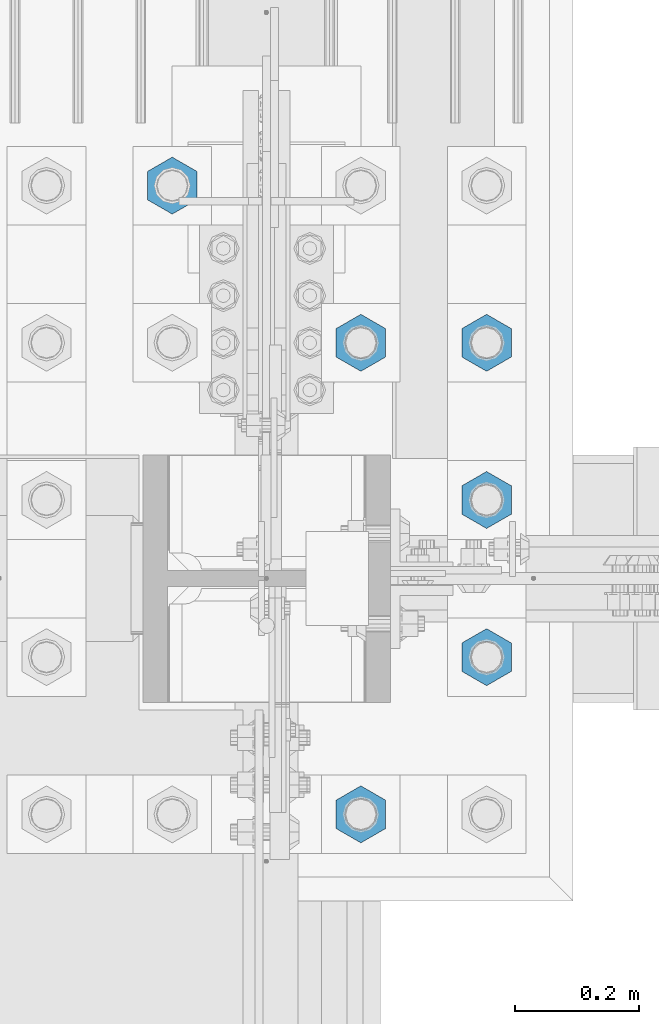
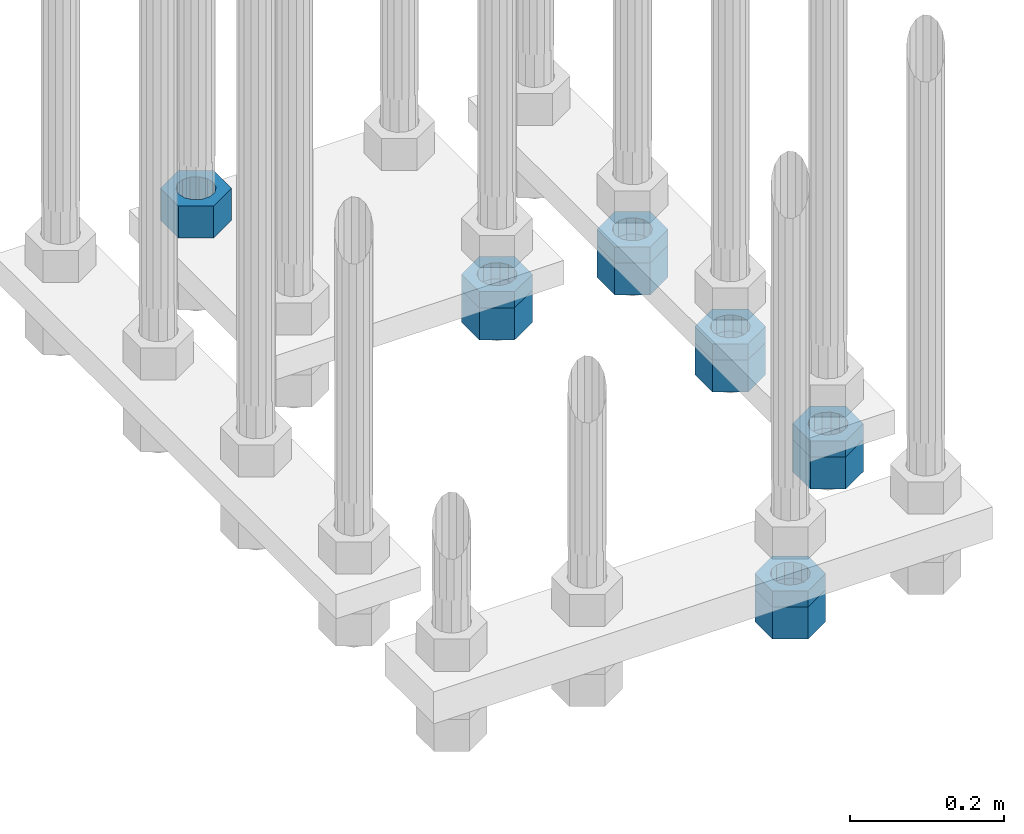
# One storey, part 2369 of 3843: 11 beams, 1 element without a shape of its own.
"""IFC2X3 building model written with IfcOpenShell, lengths in millimetres."""

from ifc_helpers import new_model, si_unit, frame, origin_with_axes, place, context, subcontext, project, spatial, faceted_brep, material, type_object, element, aggregate, save


model = new_model("IFC2X3")

# Units and contexts
model_context = context("Model", 3, precision=1e-05, world=origin_with_axes())
body_context = subcontext(model_context, "Body", "Model", "MODEL_VIEW")
ifc_project = project(units=[si_unit("LENGTHUNIT", "METRE", prefix="MILLI"), si_unit("AREAUNIT", "SQUARE_METRE"), si_unit("VOLUMEUNIT", "CUBIC_METRE"), si_unit("MASSUNIT", "GRAM", prefix="KILO"), si_unit("TIMEUNIT", "SECOND"), si_unit("PLANEANGLEUNIT", "RADIAN"), si_unit("SOLIDANGLEUNIT", "STERADIAN"), si_unit("THERMODYNAMICTEMPERATUREUNIT", "DEGREE_CELSIUS"), si_unit("LUMINOUSINTENSITYUNIT", "LUMEN")], contexts=[model_context])

# Site, building, storey
site_placement = place(None, origin_with_axes())
site = spatial("IfcSite", under=ifc_project, at=site_placement, CompositionType="ELEMENT")
building_placement = place(site_placement, origin_with_axes())
building = spatial("IfcBuilding", under=site, at=building_placement, Name="Undefined", CompositionType="ELEMENT")
storey_placement = place(building_placement, origin_with_axes())
storey = spatial("IfcBuildingStorey", under=building, at=storey_placement, Name="Undefined", CompositionType="ELEMENT", Elevation=0.0)

# Assembly, beams
assembly_placement = place(storey_placement, origin_with_axes())
assembly = element("IfcElementAssembly", 1, at=assembly_placement, inside=storey, Name="TEMPLATE", AssemblyPlace="NOTDEFINED", PredefinedType="RIGID_FRAME")
ifc_material = material(Name="STEEL/A572-50")
beam_type_1 = type_object("IfcBeamType", Name="2_HALF_NUT", PredefinedType="NOTDEFINED")
beam_1_placement = place(assembly_placement, frame((36728.4, 66890.9, 29057.6), z_axis=(1.0, 0.0, 0.0), x_axis=(0.0, 0.0, -1.0)))
beam_1 = element("IfcBeam", 2, at=beam_1_placement, type_object=beam_type_1, material=ifc_material, Name="NUT", ObjectType="2_HALF_NUT", context=body_context, shape_type="Brep", body=[
    faceted_brep([(0.0, -46.0369987487793, 0.0), (0.0, -23.0184993743896, -39.869213104248), (25.4000000000015, -23.0184993743896, -39.869213104248), (25.4000000000015, -46.0369987487793, 0.0), (0.0, 23.0184993743896, -39.869213104248), (25.4000000000015, 23.0184993743896, -39.869213104248), (0.0, 46.0369987487793, 0.0), (25.4000000000015, 46.0369987487793, 0.0), (0.0, 23.0184993743896, 39.869213104248), (25.4000000000015, 23.0184993743896, 39.869213104248), (0.0, -23.0184993743896, 39.869213104248), (25.4000000000015, -23.0184993743896, 39.869213104248), (0.0, 0.0, 26.1940002441406), (0.0, 11.3650617044477, 23.5999013092805), (25.4000000000015, 11.3650617044477, 23.5999013092805), (25.4000000000015, 0.0, 26.1940002441406), (0.0, 20.4791109456419, 16.3316083006721), (25.4000000000015, 20.4791109456419, 16.3316083006721), (0.0, 25.5370200498292, 5.82867859874386), (25.4000000000015, 25.5370200498292, 5.82867859874386), (0.0, 25.5370200498292, -5.82867859874386), (25.4000000000015, 25.5370200498292, -5.82867859874386), (0.0, 20.4791109456419, -16.3316083006721), (25.4000000000015, 20.4791109456419, -16.3316083006721), (0.0, 11.3650617044477, -23.5999013092805), (25.4000000000015, 11.3650617044477, -23.5999013092805), (0.0, 0.0, -26.1940002441406), (25.4000000000015, 0.0, -26.1940002441406), (0.0, -11.3650617044477, -23.5999013092805), (25.4000000000015, -11.3650617044477, -23.5999013092805), (0.0, -20.4791109456419, -16.3316083006721), (25.4000000000015, -20.4791109456419, -16.3316083006721), (0.0, -25.5370200498292, -5.82867859874386), (25.4000000000015, -25.5370200498292, -5.82867859874386), (0.0, -25.5370200498292, 5.82867859874386), (25.4000000000015, -25.5370200498292, 5.82867859874386), (0.0, -20.4791109456419, 16.3316083006721), (25.4000000000015, -20.4791109456419, 16.3316083006721), (0.0, -11.3650617044477, 23.5999013092805), (25.4000000000015, -11.3650617044477, 23.5999013092805)], [[[0, 1, 2, 3]], [[1, 4, 5, 2]], [[4, 6, 7, 5]], [[6, 8, 9, 7]], [[8, 10, 11, 9]], [[10, 0, 3, 11]], [[12, 13, 14, 15]], [[13, 16, 17, 14]], [[16, 18, 19, 17]], [[18, 20, 21, 19]], [[20, 22, 23, 21]], [[22, 24, 25, 23]], [[24, 26, 27, 25]], [[26, 28, 29, 27]], [[28, 30, 31, 29]], [[30, 32, 33, 31]], [[32, 34, 35, 33]], [[34, 36, 37, 35]], [[36, 38, 39, 37]], [[38, 12, 15, 39]], [[5, 7, 9, 11, 3, 2], [17, 19, 21, 23, 25, 27, 29, 31, 33, 35, 37, 39, 15, 14]], [[10, 8, 6, 4, 1, 0], [38, 36, 34, 32, 30, 28, 26, 24, 22, 20, 18, 16, 13, 12]]]),
])
beam_2_placement = place(assembly_placement, frame((36728.4, 67652.9, 29070.3), z_axis=(-1.0, 0.0, 0.0), x_axis=(0.0, 0.0, -1.0)))
beam_2 = element("IfcBeam", 3, at=beam_2_placement, type_object=beam_type_1, material=ifc_material, Name="NUT", ObjectType="2_HALF_NUT", context=body_context, shape_type="Brep", body=[
    faceted_brep([(0.0, -46.0369987487793, 0.0), (0.0, -23.0184993743896, -39.869213104248), (25.4000000000015, -23.0184993743896, -39.869213104248), (25.4000000000015, -46.0369987487793, 0.0), (0.0, 23.0184993743896, -39.869213104248), (25.4000000000015, 23.0184993743896, -39.869213104248), (0.0, 46.0369987487793, 0.0), (25.4000000000015, 46.0369987487793, 0.0), (0.0, 23.0184993743896, 39.869213104248), (25.4000000000015, 23.0184993743896, 39.869213104248), (0.0, -23.0184993743896, 39.869213104248), (25.4000000000015, -23.0184993743896, 39.869213104248), (0.0, 0.0, 26.1940002441406), (0.0, 11.3650617044477, 23.5999013092805), (25.4000000000015, 11.3650617044477, 23.5999013092805), (25.4000000000015, 0.0, 26.1940002441406), (0.0, 20.4791109456419, 16.3316083006721), (25.4000000000015, 20.4791109456419, 16.3316083006721), (0.0, 25.5370200498292, 5.82867859874386), (25.4000000000015, 25.5370200498292, 5.82867859874386), (0.0, 25.5370200498292, -5.82867859874386), (25.4000000000015, 25.5370200498292, -5.82867859874386), (0.0, 20.4791109456419, -16.3316083006721), (25.4000000000015, 20.4791109456419, -16.3316083006721), (0.0, 11.3650617044477, -23.5999013092805), (25.4000000000015, 11.3650617044477, -23.5999013092805), (0.0, 0.0, -26.1940002441406), (25.4000000000015, 0.0, -26.1940002441406), (0.0, -11.3650617044477, -23.5999013092805), (25.4000000000015, -11.3650617044477, -23.5999013092805), (0.0, -20.4791109456419, -16.3316083006721), (25.4000000000015, -20.4791109456419, -16.3316083006721), (0.0, -25.5370200498292, -5.82867859874386), (25.4000000000015, -25.5370200498292, -5.82867859874386), (0.0, -25.5370200498292, 5.82867859874386), (25.4000000000015, -25.5370200498292, 5.82867859874386), (0.0, -20.4791109456419, 16.3316083006721), (25.4000000000015, -20.4791109456419, 16.3316083006721), (0.0, -11.3650617044477, 23.5999013092805), (25.4000000000015, -11.3650617044477, 23.5999013092805)], [[[0, 1, 2, 3]], [[1, 4, 5, 2]], [[4, 6, 7, 5]], [[6, 8, 9, 7]], [[8, 10, 11, 9]], [[10, 0, 3, 11]], [[12, 13, 14, 15]], [[13, 16, 17, 14]], [[16, 18, 19, 17]], [[18, 20, 21, 19]], [[20, 22, 23, 21]], [[22, 24, 25, 23]], [[24, 26, 27, 25]], [[26, 28, 29, 27]], [[28, 30, 31, 29]], [[30, 32, 33, 31]], [[32, 34, 35, 33]], [[34, 36, 37, 35]], [[36, 38, 39, 37]], [[38, 12, 15, 39]], [[5, 7, 9, 11, 3, 2], [17, 19, 21, 23, 25, 27, 29, 31, 33, 35, 37, 39, 15, 14]], [[10, 8, 6, 4, 1, 0], [38, 36, 34, 32, 30, 28, 26, 24, 22, 20, 18, 16, 13, 12]]]),
])
beam_3_placement = place(assembly_placement, frame((36931.6, 67144.9, 29070.3), z_axis=(1.0, 0.0, 0.0), x_axis=(0.0, 0.0, -1.0)))
beam_3 = element("IfcBeam", 4, at=beam_3_placement, type_object=beam_type_1, material=ifc_material, Name="NUT", ObjectType="2_HALF_NUT", context=body_context, shape_type="Brep", body=[
    faceted_brep([(0.0, -46.0369987487793, 0.0), (0.0, -23.0184993743896, -39.869213104248), (25.4000000000015, -23.0184993743896, -39.869213104248), (25.4000000000015, -46.0369987487793, 0.0), (0.0, 23.0184993743896, -39.869213104248), (25.4000000000015, 23.0184993743896, -39.869213104248), (0.0, 46.0369987487793, 0.0), (25.4000000000015, 46.0369987487793, 0.0), (0.0, 23.0184993743896, 39.869213104248), (25.4000000000015, 23.0184993743896, 39.869213104248), (0.0, -23.0184993743896, 39.869213104248), (25.4000000000015, -23.0184993743896, 39.869213104248), (0.0, 0.0, 26.1940002441406), (0.0, 11.3650617044477, 23.5999013092805), (25.4000000000015, 11.3650617044477, 23.5999013092805), (25.4000000000015, 0.0, 26.1940002441406), (0.0, 20.4791109456419, 16.3316083006721), (25.4000000000015, 20.4791109456419, 16.3316083006721), (0.0, 25.5370200498292, 5.82867859874386), (25.4000000000015, 25.5370200498292, 5.82867859874386), (0.0, 25.5370200498292, -5.82867859874386), (25.4000000000015, 25.5370200498292, -5.82867859874386), (0.0, 20.4791109456419, -16.3316083006721), (25.4000000000015, 20.4791109456419, -16.3316083006721), (0.0, 11.3650617044477, -23.5999013092805), (25.4000000000015, 11.3650617044477, -23.5999013092805), (0.0, 0.0, -26.1940002441406), (25.4000000000015, 0.0, -26.1940002441406), (0.0, -11.3650617044477, -23.5999013092805), (25.4000000000015, -11.3650617044477, -23.5999013092805), (0.0, -20.4791109456419, -16.3316083006721), (25.4000000000015, -20.4791109456419, -16.3316083006721), (0.0, -25.5370200498292, -5.82867859874386), (25.4000000000015, -25.5370200498292, -5.82867859874386), (0.0, -25.5370200498292, 5.82867859874386), (25.4000000000015, -25.5370200498292, 5.82867859874386), (0.0, -20.4791109456419, 16.3316083006721), (25.4000000000015, -20.4791109456419, 16.3316083006721), (0.0, -11.3650617044477, 23.5999013092805), (25.4000000000015, -11.3650617044477, 23.5999013092805)], [[[0, 1, 2, 3]], [[1, 4, 5, 2]], [[4, 6, 7, 5]], [[6, 8, 9, 7]], [[8, 10, 11, 9]], [[10, 0, 3, 11]], [[12, 13, 14, 15]], [[13, 16, 17, 14]], [[16, 18, 19, 17]], [[18, 20, 21, 19]], [[20, 22, 23, 21]], [[22, 24, 25, 23]], [[24, 26, 27, 25]], [[26, 28, 29, 27]], [[28, 30, 31, 29]], [[30, 32, 33, 31]], [[32, 34, 35, 33]], [[34, 36, 37, 35]], [[36, 38, 39, 37]], [[38, 12, 15, 39]], [[5, 7, 9, 11, 3, 2], [17, 19, 21, 23, 25, 27, 29, 31, 33, 35, 37, 39, 15, 14]], [[10, 8, 6, 4, 1, 0], [38, 36, 34, 32, 30, 28, 26, 24, 22, 20, 18, 16, 13, 12]]]),
])
beam_4_placement = place(assembly_placement, frame((36931.6, 67398.9, 29070.3), z_axis=(1.0, 0.0, 0.0), x_axis=(0.0, 0.0, -1.0)))
beam_4 = element("IfcBeam", 5, at=beam_4_placement, type_object=beam_type_1, material=ifc_material, Name="NUT", ObjectType="2_HALF_NUT", context=body_context, shape_type="Brep", body=[
    faceted_brep([(0.0, -46.0369987487793, 0.0), (0.0, -23.0184993743896, -39.869213104248), (25.4000000000015, -23.0184993743896, -39.869213104248), (25.4000000000015, -46.0369987487793, 0.0), (0.0, 23.0184993743896, -39.869213104248), (25.4000000000015, 23.0184993743896, -39.869213104248), (0.0, 46.0369987487793, 0.0), (25.4000000000015, 46.0369987487793, 0.0), (0.0, 23.0184993743896, 39.869213104248), (25.4000000000015, 23.0184993743896, 39.869213104248), (0.0, -23.0184993743896, 39.869213104248), (25.4000000000015, -23.0184993743896, 39.869213104248), (0.0, 0.0, 26.1940002441406), (0.0, 11.3650617044477, 23.5999013092805), (25.4000000000015, 11.3650617044477, 23.5999013092805), (25.4000000000015, 0.0, 26.1940002441406), (0.0, 20.4791109456419, 16.3316083006721), (25.4000000000015, 20.4791109456419, 16.3316083006721), (0.0, 25.5370200498292, 5.82867859874386), (25.4000000000015, 25.5370200498292, 5.82867859874386), (0.0, 25.5370200498292, -5.82867859874386), (25.4000000000015, 25.5370200498292, -5.82867859874386), (0.0, 20.4791109456419, -16.3316083006721), (25.4000000000015, 20.4791109456419, -16.3316083006721), (0.0, 11.3650617044477, -23.5999013092805), (25.4000000000015, 11.3650617044477, -23.5999013092805), (0.0, 0.0, -26.1940002441406), (25.4000000000015, 0.0, -26.1940002441406), (0.0, -11.3650617044477, -23.5999013092805), (25.4000000000015, -11.3650617044477, -23.5999013092805), (0.0, -20.4791109456419, -16.3316083006721), (25.4000000000015, -20.4791109456419, -16.3316083006721), (0.0, -25.5370200498292, -5.82867859874386), (25.4000000000015, -25.5370200498292, -5.82867859874386), (0.0, -25.5370200498292, 5.82867859874386), (25.4000000000015, -25.5370200498292, 5.82867859874386), (0.0, -20.4791109456419, 16.3316083006721), (25.4000000000015, -20.4791109456419, 16.3316083006721), (0.0, -11.3650617044477, 23.5999013092805), (25.4000000000015, -11.3650617044477, 23.5999013092805)], [[[0, 1, 2, 3]], [[1, 4, 5, 2]], [[4, 6, 7, 5]], [[6, 8, 9, 7]], [[8, 10, 11, 9]], [[10, 0, 3, 11]], [[12, 13, 14, 15]], [[13, 16, 17, 14]], [[16, 18, 19, 17]], [[18, 20, 21, 19]], [[20, 22, 23, 21]], [[22, 24, 25, 23]], [[24, 26, 27, 25]], [[26, 28, 29, 27]], [[28, 30, 31, 29]], [[30, 32, 33, 31]], [[32, 34, 35, 33]], [[34, 36, 37, 35]], [[36, 38, 39, 37]], [[38, 12, 15, 39]], [[5, 7, 9, 11, 3, 2], [17, 19, 21, 23, 25, 27, 29, 31, 33, 35, 37, 39, 15, 14]], [[10, 8, 6, 4, 1, 0], [38, 36, 34, 32, 30, 28, 26, 24, 22, 20, 18, 16, 13, 12]]]),
])
beam_5_placement = place(assembly_placement, frame((36931.6, 67652.9, 29070.3), z_axis=(-1.0, 0.0, 0.0), x_axis=(0.0, 0.0, -1.0)))
beam_5 = element("IfcBeam", 6, at=beam_5_placement, type_object=beam_type_1, material=ifc_material, Name="NUT", ObjectType="2_HALF_NUT", context=body_context, shape_type="Brep", body=[
    faceted_brep([(0.0, -46.0369987487793, 0.0), (0.0, -23.0184993743896, -39.869213104248), (25.4000000000015, -23.0184993743896, -39.869213104248), (25.4000000000015, -46.0369987487793, 0.0), (0.0, 23.0184993743896, -39.869213104248), (25.4000000000015, 23.0184993743896, -39.869213104248), (0.0, 46.0369987487793, 0.0), (25.4000000000015, 46.0369987487793, 0.0), (0.0, 23.0184993743896, 39.869213104248), (25.4000000000015, 23.0184993743896, 39.869213104248), (0.0, -23.0184993743896, 39.869213104248), (25.4000000000015, -23.0184993743896, 39.869213104248), (0.0, 0.0, 26.1940002441406), (0.0, 11.3650617044477, 23.5999013092805), (25.4000000000015, 11.3650617044477, 23.5999013092805), (25.4000000000015, 0.0, 26.1940002441406), (0.0, 20.4791109456419, 16.3316083006721), (25.4000000000015, 20.4791109456419, 16.3316083006721), (0.0, 25.5370200498292, 5.82867859874386), (25.4000000000015, 25.5370200498292, 5.82867859874386), (0.0, 25.5370200498292, -5.82867859874386), (25.4000000000015, 25.5370200498292, -5.82867859874386), (0.0, 20.4791109456419, -16.3316083006721), (25.4000000000015, 20.4791109456419, -16.3316083006721), (0.0, 11.3650617044477, -23.5999013092805), (25.4000000000015, 11.3650617044477, -23.5999013092805), (0.0, 0.0, -26.1940002441406), (25.4000000000015, 0.0, -26.1940002441406), (0.0, -11.3650617044477, -23.5999013092805), (25.4000000000015, -11.3650617044477, -23.5999013092805), (0.0, -20.4791109456419, -16.3316083006721), (25.4000000000015, -20.4791109456419, -16.3316083006721), (0.0, -25.5370200498292, -5.82867859874386), (25.4000000000015, -25.5370200498292, -5.82867859874386), (0.0, -25.5370200498292, 5.82867859874386), (25.4000000000015, -25.5370200498292, 5.82867859874386), (0.0, -20.4791109456419, 16.3316083006721), (25.4000000000015, -20.4791109456419, 16.3316083006721), (0.0, -11.3650617044477, 23.5999013092805), (25.4000000000015, -11.3650617044477, 23.5999013092805)], [[[0, 1, 2, 3]], [[1, 4, 5, 2]], [[4, 6, 7, 5]], [[6, 8, 9, 7]], [[8, 10, 11, 9]], [[10, 0, 3, 11]], [[12, 13, 14, 15]], [[13, 16, 17, 14]], [[16, 18, 19, 17]], [[18, 20, 21, 19]], [[20, 22, 23, 21]], [[22, 24, 25, 23]], [[24, 26, 27, 25]], [[26, 28, 29, 27]], [[28, 30, 31, 29]], [[30, 32, 33, 31]], [[32, 34, 35, 33]], [[34, 36, 37, 35]], [[36, 38, 39, 37]], [[38, 12, 15, 39]], [[5, 7, 9, 11, 3, 2], [17, 19, 21, 23, 25, 27, 29, 31, 33, 35, 37, 39, 15, 14]], [[10, 8, 6, 4, 1, 0], [38, 36, 34, 32, 30, 28, 26, 24, 22, 20, 18, 16, 13, 12]]]),
])
beam_type_2 = type_object("IfcBeamType", Name="2_HEAVY_HEX_NUT", PredefinedType="NOTDEFINED")
beam_6_placement = place(assembly_placement, frame((36423.6, 67906.9, 29159.2), z_axis=(-1.0, 0.0, 0.0), x_axis=(0.0, 0.0, -1.0)))
beam_6 = element("IfcBeam", 7, at=beam_6_placement, type_object=beam_type_2, material=ifc_material, Name="NUT", ObjectType="2_HEAVY_HEX_NUT", context=body_context, shape_type="Brep", body=[
    faceted_brep([(0.0, -46.0369987487793, 0.0), (0.0, -23.0184993743896, -39.869213104248), (50.7999999999993, -23.0184993743896, -39.869213104248), (50.7999999999993, -46.0369987487793, 0.0), (0.0, 23.0184993743896, -39.869213104248), (50.7999999999993, 23.0184993743896, -39.869213104248), (0.0, 46.0369987487793, 0.0), (50.7999999999993, 46.0369987487793, 0.0), (0.0, 23.0184993743896, 39.869213104248), (50.7999999999993, 23.0184993743896, 39.869213104248), (0.0, -23.0184993743896, 39.869213104248), (50.7999999999993, -23.0184993743896, 39.869213104248), (0.0, 0.0, 26.1940002441406), (0.0, 11.3650617044477, 23.5999013092805), (50.7999999999993, 11.3650617044477, 23.5999013092805), (50.7999999999993, 0.0, 26.1940002441406), (0.0, 20.4791109456419, 16.3316083006721), (50.7999999999993, 20.4791109456419, 16.3316083006721), (0.0, 25.5370200498292, 5.82867859874386), (50.7999999999993, 25.5370200498292, 5.82867859874386), (0.0, 25.5370200498292, -5.82867859874386), (50.7999999999993, 25.5370200498292, -5.82867859874386), (0.0, 20.4791109456419, -16.3316083006721), (50.7999999999993, 20.4791109456419, -16.3316083006721), (0.0, 11.3650617044477, -23.5999013092805), (50.7999999999993, 11.3650617044477, -23.5999013092805), (0.0, 0.0, -26.1940002441406), (50.7999999999993, 0.0, -26.1940002441406), (0.0, -11.3650617044477, -23.5999013092805), (50.7999999999993, -11.3650617044477, -23.5999013092805), (0.0, -20.4791109456419, -16.3316083006721), (50.7999999999993, -20.4791109456419, -16.3316083006721), (0.0, -25.5370200498292, -5.82867859874386), (50.7999999999993, -25.5370200498292, -5.82867859874386), (0.0, -25.5370200498292, 5.82867859874386), (50.7999999999993, -25.5370200498292, 5.82867859874386), (0.0, -20.4791109456419, 16.3316083006721), (50.7999999999993, -20.4791109456419, 16.3316083006721), (0.0, -11.3650617044477, 23.5999013092805), (50.7999999999993, -11.3650617044477, 23.5999013092805)], [[[0, 1, 2, 3]], [[1, 4, 5, 2]], [[4, 6, 7, 5]], [[6, 8, 9, 7]], [[8, 10, 11, 9]], [[10, 0, 3, 11]], [[12, 13, 14, 15]], [[13, 16, 17, 14]], [[16, 18, 19, 17]], [[18, 20, 21, 19]], [[20, 22, 23, 21]], [[22, 24, 25, 23]], [[24, 26, 27, 25]], [[26, 28, 29, 27]], [[28, 30, 31, 29]], [[30, 32, 33, 31]], [[32, 34, 35, 33]], [[34, 36, 37, 35]], [[36, 38, 39, 37]], [[38, 12, 15, 39]], [[5, 7, 9, 11, 3, 2], [17, 19, 21, 23, 25, 27, 29, 31, 33, 35, 37, 39, 15, 14]], [[10, 8, 6, 4, 1, 0], [38, 36, 34, 32, 30, 28, 26, 24, 22, 20, 18, 16, 13, 12]]]),
])
beam_7_placement = place(assembly_placement, frame((36728.4, 66890.9, 29032.2), z_axis=(1.0, 0.0, 0.0), x_axis=(0.0, 0.0, -1.0)))
beam_7 = element("IfcBeam", 8, at=beam_7_placement, type_object=beam_type_2, material=ifc_material, Name="NUT", ObjectType="2_HEAVY_HEX_NUT", context=body_context, shape_type="Brep", body=[
    faceted_brep([(0.0, -46.0369987487793, 0.0), (0.0, -23.0184993743896, -39.869213104248), (50.7999999999993, -23.0184993743896, -39.869213104248), (50.7999999999993, -46.0369987487793, 0.0), (0.0, 23.0184993743896, -39.869213104248), (50.7999999999993, 23.0184993743896, -39.869213104248), (0.0, 46.0369987487793, 0.0), (50.7999999999993, 46.0369987487793, 0.0), (0.0, 23.0184993743896, 39.869213104248), (50.7999999999993, 23.0184993743896, 39.869213104248), (0.0, -23.0184993743896, 39.869213104248), (50.7999999999993, -23.0184993743896, 39.869213104248), (0.0, 0.0, 26.1940002441406), (0.0, 11.3650617044477, 23.5999013092805), (50.7999999999993, 11.3650617044477, 23.5999013092805), (50.7999999999993, 0.0, 26.1940002441406), (0.0, 20.4791109456419, 16.3316083006721), (50.7999999999993, 20.4791109456419, 16.3316083006721), (0.0, 25.5370200498292, 5.82867859874386), (50.7999999999993, 25.5370200498292, 5.82867859874386), (0.0, 25.5370200498292, -5.82867859874386), (50.7999999999993, 25.5370200498292, -5.82867859874386), (0.0, 20.4791109456419, -16.3316083006721), (50.7999999999993, 20.4791109456419, -16.3316083006721), (0.0, 11.3650617044477, -23.5999013092805), (50.7999999999993, 11.3650617044477, -23.5999013092805), (0.0, 0.0, -26.1940002441406), (50.7999999999993, 0.0, -26.1940002441406), (0.0, -11.3650617044477, -23.5999013092805), (50.7999999999993, -11.3650617044477, -23.5999013092805), (0.0, -20.4791109456419, -16.3316083006721), (50.7999999999993, -20.4791109456419, -16.3316083006721), (0.0, -25.5370200498292, -5.82867859874386), (50.7999999999993, -25.5370200498292, -5.82867859874386), (0.0, -25.5370200498292, 5.82867859874386), (50.7999999999993, -25.5370200498292, 5.82867859874386), (0.0, -20.4791109456419, 16.3316083006721), (50.7999999999993, -20.4791109456419, 16.3316083006721), (0.0, -11.3650617044477, 23.5999013092805), (50.7999999999993, -11.3650617044477, 23.5999013092805)], [[[0, 1, 2, 3]], [[1, 4, 5, 2]], [[4, 6, 7, 5]], [[6, 8, 9, 7]], [[8, 10, 11, 9]], [[10, 0, 3, 11]], [[12, 13, 14, 15]], [[13, 16, 17, 14]], [[16, 18, 19, 17]], [[18, 20, 21, 19]], [[20, 22, 23, 21]], [[22, 24, 25, 23]], [[24, 26, 27, 25]], [[26, 28, 29, 27]], [[28, 30, 31, 29]], [[30, 32, 33, 31]], [[32, 34, 35, 33]], [[34, 36, 37, 35]], [[36, 38, 39, 37]], [[38, 12, 15, 39]], [[5, 7, 9, 11, 3, 2], [17, 19, 21, 23, 25, 27, 29, 31, 33, 35, 37, 39, 15, 14]], [[10, 8, 6, 4, 1, 0], [38, 36, 34, 32, 30, 28, 26, 24, 22, 20, 18, 16, 13, 12]]]),
])
beam_8_placement = place(assembly_placement, frame((36728.4, 67652.9, 29044.9), z_axis=(-1.0, 0.0, 0.0), x_axis=(0.0, 0.0, -1.0)))
beam_8 = element("IfcBeam", 9, at=beam_8_placement, type_object=beam_type_2, material=ifc_material, Name="NUT", ObjectType="2_HEAVY_HEX_NUT", context=body_context, shape_type="Brep", body=[
    faceted_brep([(0.0, -46.0369987487793, 0.0), (0.0, -23.0184993743896, -39.869213104248), (50.7999999999993, -23.0184993743896, -39.869213104248), (50.7999999999993, -46.0369987487793, 0.0), (0.0, 23.0184993743896, -39.869213104248), (50.7999999999993, 23.0184993743896, -39.869213104248), (0.0, 46.0369987487793, 0.0), (50.7999999999993, 46.0369987487793, 0.0), (0.0, 23.0184993743896, 39.869213104248), (50.7999999999993, 23.0184993743896, 39.869213104248), (0.0, -23.0184993743896, 39.869213104248), (50.7999999999993, -23.0184993743896, 39.869213104248), (0.0, 0.0, 26.1940002441406), (0.0, 11.3650617044477, 23.5999013092805), (50.7999999999993, 11.3650617044477, 23.5999013092805), (50.7999999999993, 0.0, 26.1940002441406), (0.0, 20.4791109456419, 16.3316083006721), (50.7999999999993, 20.4791109456419, 16.3316083006721), (0.0, 25.5370200498292, 5.82867859874386), (50.7999999999993, 25.5370200498292, 5.82867859874386), (0.0, 25.5370200498292, -5.82867859874386), (50.7999999999993, 25.5370200498292, -5.82867859874386), (0.0, 20.4791109456419, -16.3316083006721), (50.7999999999993, 20.4791109456419, -16.3316083006721), (0.0, 11.3650617044477, -23.5999013092805), (50.7999999999993, 11.3650617044477, -23.5999013092805), (0.0, 0.0, -26.1940002441406), (50.7999999999993, 0.0, -26.1940002441406), (0.0, -11.3650617044477, -23.5999013092805), (50.7999999999993, -11.3650617044477, -23.5999013092805), (0.0, -20.4791109456419, -16.3316083006721), (50.7999999999993, -20.4791109456419, -16.3316083006721), (0.0, -25.5370200498292, -5.82867859874386), (50.7999999999993, -25.5370200498292, -5.82867859874386), (0.0, -25.5370200498292, 5.82867859874386), (50.7999999999993, -25.5370200498292, 5.82867859874386), (0.0, -20.4791109456419, 16.3316083006721), (50.7999999999993, -20.4791109456419, 16.3316083006721), (0.0, -11.3650617044477, 23.5999013092805), (50.7999999999993, -11.3650617044477, 23.5999013092805)], [[[0, 1, 2, 3]], [[1, 4, 5, 2]], [[4, 6, 7, 5]], [[6, 8, 9, 7]], [[8, 10, 11, 9]], [[10, 0, 3, 11]], [[12, 13, 14, 15]], [[13, 16, 17, 14]], [[16, 18, 19, 17]], [[18, 20, 21, 19]], [[20, 22, 23, 21]], [[22, 24, 25, 23]], [[24, 26, 27, 25]], [[26, 28, 29, 27]], [[28, 30, 31, 29]], [[30, 32, 33, 31]], [[32, 34, 35, 33]], [[34, 36, 37, 35]], [[36, 38, 39, 37]], [[38, 12, 15, 39]], [[5, 7, 9, 11, 3, 2], [17, 19, 21, 23, 25, 27, 29, 31, 33, 35, 37, 39, 15, 14]], [[10, 8, 6, 4, 1, 0], [38, 36, 34, 32, 30, 28, 26, 24, 22, 20, 18, 16, 13, 12]]]),
])
beam_9_placement = place(assembly_placement, frame((36931.6, 67144.9, 29044.9), z_axis=(1.0, 0.0, 0.0), x_axis=(0.0, 0.0, -1.0)))
beam_9 = element("IfcBeam", 10, at=beam_9_placement, type_object=beam_type_2, material=ifc_material, Name="NUT", ObjectType="2_HEAVY_HEX_NUT", context=body_context, shape_type="Brep", body=[
    faceted_brep([(0.0, -46.0369987487793, 0.0), (0.0, -23.0184993743896, -39.869213104248), (50.7999999999993, -23.0184993743896, -39.869213104248), (50.7999999999993, -46.0369987487793, 0.0), (0.0, 23.0184993743896, -39.869213104248), (50.7999999999993, 23.0184993743896, -39.869213104248), (0.0, 46.0369987487793, 0.0), (50.7999999999993, 46.0369987487793, 0.0), (0.0, 23.0184993743896, 39.869213104248), (50.7999999999993, 23.0184993743896, 39.869213104248), (0.0, -23.0184993743896, 39.869213104248), (50.7999999999993, -23.0184993743896, 39.869213104248), (0.0, 0.0, 26.1940002441406), (0.0, 11.3650617044477, 23.5999013092805), (50.7999999999993, 11.3650617044477, 23.5999013092805), (50.7999999999993, 0.0, 26.1940002441406), (0.0, 20.4791109456419, 16.3316083006721), (50.7999999999993, 20.4791109456419, 16.3316083006721), (0.0, 25.5370200498292, 5.82867859874386), (50.7999999999993, 25.5370200498292, 5.82867859874386), (0.0, 25.5370200498292, -5.82867859874386), (50.7999999999993, 25.5370200498292, -5.82867859874386), (0.0, 20.4791109456419, -16.3316083006721), (50.7999999999993, 20.4791109456419, -16.3316083006721), (0.0, 11.3650617044477, -23.5999013092805), (50.7999999999993, 11.3650617044477, -23.5999013092805), (0.0, 0.0, -26.1940002441406), (50.7999999999993, 0.0, -26.1940002441406), (0.0, -11.3650617044477, -23.5999013092805), (50.7999999999993, -11.3650617044477, -23.5999013092805), (0.0, -20.4791109456419, -16.3316083006721), (50.7999999999993, -20.4791109456419, -16.3316083006721), (0.0, -25.5370200498292, -5.82867859874386), (50.7999999999993, -25.5370200498292, -5.82867859874386), (0.0, -25.5370200498292, 5.82867859874386), (50.7999999999993, -25.5370200498292, 5.82867859874386), (0.0, -20.4791109456419, 16.3316083006721), (50.7999999999993, -20.4791109456419, 16.3316083006721), (0.0, -11.3650617044477, 23.5999013092805), (50.7999999999993, -11.3650617044477, 23.5999013092805)], [[[0, 1, 2, 3]], [[1, 4, 5, 2]], [[4, 6, 7, 5]], [[6, 8, 9, 7]], [[8, 10, 11, 9]], [[10, 0, 3, 11]], [[12, 13, 14, 15]], [[13, 16, 17, 14]], [[16, 18, 19, 17]], [[18, 20, 21, 19]], [[20, 22, 23, 21]], [[22, 24, 25, 23]], [[24, 26, 27, 25]], [[26, 28, 29, 27]], [[28, 30, 31, 29]], [[30, 32, 33, 31]], [[32, 34, 35, 33]], [[34, 36, 37, 35]], [[36, 38, 39, 37]], [[38, 12, 15, 39]], [[5, 7, 9, 11, 3, 2], [17, 19, 21, 23, 25, 27, 29, 31, 33, 35, 37, 39, 15, 14]], [[10, 8, 6, 4, 1, 0], [38, 36, 34, 32, 30, 28, 26, 24, 22, 20, 18, 16, 13, 12]]]),
])
beam_10_placement = place(assembly_placement, frame((36931.6, 67398.9, 29044.9), z_axis=(1.0, 0.0, 0.0), x_axis=(0.0, 0.0, -1.0)))
beam_10 = element("IfcBeam", 11, at=beam_10_placement, type_object=beam_type_2, material=ifc_material, Name="NUT", ObjectType="2_HEAVY_HEX_NUT", context=body_context, shape_type="Brep", body=[
    faceted_brep([(0.0, -46.0369987487793, 0.0), (0.0, -23.0184993743896, -39.869213104248), (50.7999999999993, -23.0184993743896, -39.869213104248), (50.7999999999993, -46.0369987487793, 0.0), (0.0, 23.0184993743896, -39.869213104248), (50.7999999999993, 23.0184993743896, -39.869213104248), (0.0, 46.0369987487793, 0.0), (50.7999999999993, 46.0369987487793, 0.0), (0.0, 23.0184993743896, 39.869213104248), (50.7999999999993, 23.0184993743896, 39.869213104248), (0.0, -23.0184993743896, 39.869213104248), (50.7999999999993, -23.0184993743896, 39.869213104248), (0.0, 0.0, 26.1940002441406), (0.0, 11.3650617044477, 23.5999013092805), (50.7999999999993, 11.3650617044477, 23.5999013092805), (50.7999999999993, 0.0, 26.1940002441406), (0.0, 20.4791109456419, 16.3316083006721), (50.7999999999993, 20.4791109456419, 16.3316083006721), (0.0, 25.5370200498292, 5.82867859874386), (50.7999999999993, 25.5370200498292, 5.82867859874386), (0.0, 25.5370200498292, -5.82867859874386), (50.7999999999993, 25.5370200498292, -5.82867859874386), (0.0, 20.4791109456419, -16.3316083006721), (50.7999999999993, 20.4791109456419, -16.3316083006721), (0.0, 11.3650617044477, -23.5999013092805), (50.7999999999993, 11.3650617044477, -23.5999013092805), (0.0, 0.0, -26.1940002441406), (50.7999999999993, 0.0, -26.1940002441406), (0.0, -11.3650617044477, -23.5999013092805), (50.7999999999993, -11.3650617044477, -23.5999013092805), (0.0, -20.4791109456419, -16.3316083006721), (50.7999999999993, -20.4791109456419, -16.3316083006721), (0.0, -25.5370200498292, -5.82867859874386), (50.7999999999993, -25.5370200498292, -5.82867859874386), (0.0, -25.5370200498292, 5.82867859874386), (50.7999999999993, -25.5370200498292, 5.82867859874386), (0.0, -20.4791109456419, 16.3316083006721), (50.7999999999993, -20.4791109456419, 16.3316083006721), (0.0, -11.3650617044477, 23.5999013092805), (50.7999999999993, -11.3650617044477, 23.5999013092805)], [[[0, 1, 2, 3]], [[1, 4, 5, 2]], [[4, 6, 7, 5]], [[6, 8, 9, 7]], [[8, 10, 11, 9]], [[10, 0, 3, 11]], [[12, 13, 14, 15]], [[13, 16, 17, 14]], [[16, 18, 19, 17]], [[18, 20, 21, 19]], [[20, 22, 23, 21]], [[22, 24, 25, 23]], [[24, 26, 27, 25]], [[26, 28, 29, 27]], [[28, 30, 31, 29]], [[30, 32, 33, 31]], [[32, 34, 35, 33]], [[34, 36, 37, 35]], [[36, 38, 39, 37]], [[38, 12, 15, 39]], [[5, 7, 9, 11, 3, 2], [17, 19, 21, 23, 25, 27, 29, 31, 33, 35, 37, 39, 15, 14]], [[10, 8, 6, 4, 1, 0], [38, 36, 34, 32, 30, 28, 26, 24, 22, 20, 18, 16, 13, 12]]]),
])
beam_11_placement = place(assembly_placement, frame((36931.6, 67652.9, 29044.9), z_axis=(-1.0, 0.0, 0.0), x_axis=(0.0, 0.0, -1.0)))
beam_11 = element("IfcBeam", 12, at=beam_11_placement, type_object=beam_type_2, material=ifc_material, Name="NUT", ObjectType="2_HEAVY_HEX_NUT", context=body_context, shape_type="Brep", body=[
    faceted_brep([(0.0, -46.0369987487793, 0.0), (0.0, -23.0184993743896, -39.869213104248), (50.7999999999993, -23.0184993743896, -39.869213104248), (50.7999999999993, -46.0369987487793, 0.0), (0.0, 23.0184993743896, -39.869213104248), (50.7999999999993, 23.0184993743896, -39.869213104248), (0.0, 46.0369987487793, 0.0), (50.7999999999993, 46.0369987487793, 0.0), (0.0, 23.0184993743896, 39.869213104248), (50.7999999999993, 23.0184993743896, 39.869213104248), (0.0, -23.0184993743896, 39.869213104248), (50.7999999999993, -23.0184993743896, 39.869213104248), (0.0, 0.0, 26.1940002441406), (0.0, 11.3650617044477, 23.5999013092805), (50.7999999999993, 11.3650617044477, 23.5999013092805), (50.7999999999993, 0.0, 26.1940002441406), (0.0, 20.4791109456419, 16.3316083006721), (50.7999999999993, 20.4791109456419, 16.3316083006721), (0.0, 25.5370200498292, 5.82867859874386), (50.7999999999993, 25.5370200498292, 5.82867859874386), (0.0, 25.5370200498292, -5.82867859874386), (50.7999999999993, 25.5370200498292, -5.82867859874386), (0.0, 20.4791109456419, -16.3316083006721), (50.7999999999993, 20.4791109456419, -16.3316083006721), (0.0, 11.3650617044477, -23.5999013092805), (50.7999999999993, 11.3650617044477, -23.5999013092805), (0.0, 0.0, -26.1940002441406), (50.7999999999993, 0.0, -26.1940002441406), (0.0, -11.3650617044477, -23.5999013092805), (50.7999999999993, -11.3650617044477, -23.5999013092805), (0.0, -20.4791109456419, -16.3316083006721), (50.7999999999993, -20.4791109456419, -16.3316083006721), (0.0, -25.5370200498292, -5.82867859874386), (50.7999999999993, -25.5370200498292, -5.82867859874386), (0.0, -25.5370200498292, 5.82867859874386), (50.7999999999993, -25.5370200498292, 5.82867859874386), (0.0, -20.4791109456419, 16.3316083006721), (50.7999999999993, -20.4791109456419, 16.3316083006721), (0.0, -11.3650617044477, 23.5999013092805), (50.7999999999993, -11.3650617044477, 23.5999013092805)], [[[0, 1, 2, 3]], [[1, 4, 5, 2]], [[4, 6, 7, 5]], [[6, 8, 9, 7]], [[8, 10, 11, 9]], [[10, 0, 3, 11]], [[12, 13, 14, 15]], [[13, 16, 17, 14]], [[16, 18, 19, 17]], [[18, 20, 21, 19]], [[20, 22, 23, 21]], [[22, 24, 25, 23]], [[24, 26, 27, 25]], [[26, 28, 29, 27]], [[28, 30, 31, 29]], [[30, 32, 33, 31]], [[32, 34, 35, 33]], [[34, 36, 37, 35]], [[36, 38, 39, 37]], [[38, 12, 15, 39]], [[5, 7, 9, 11, 3, 2], [17, 19, 21, 23, 25, 27, 29, 31, 33, 35, 37, 39, 15, 14]], [[10, 8, 6, 4, 1, 0], [38, 36, 34, 32, 30, 28, 26, 24, 22, 20, 18, 16, 13, 12]]]),
])
aggregate(assembly, [beam_6, beam_7, beam_1, beam_8, beam_2, beam_9, beam_10, beam_11, beam_3, beam_4, beam_5])

save(model, "model.ifc")
